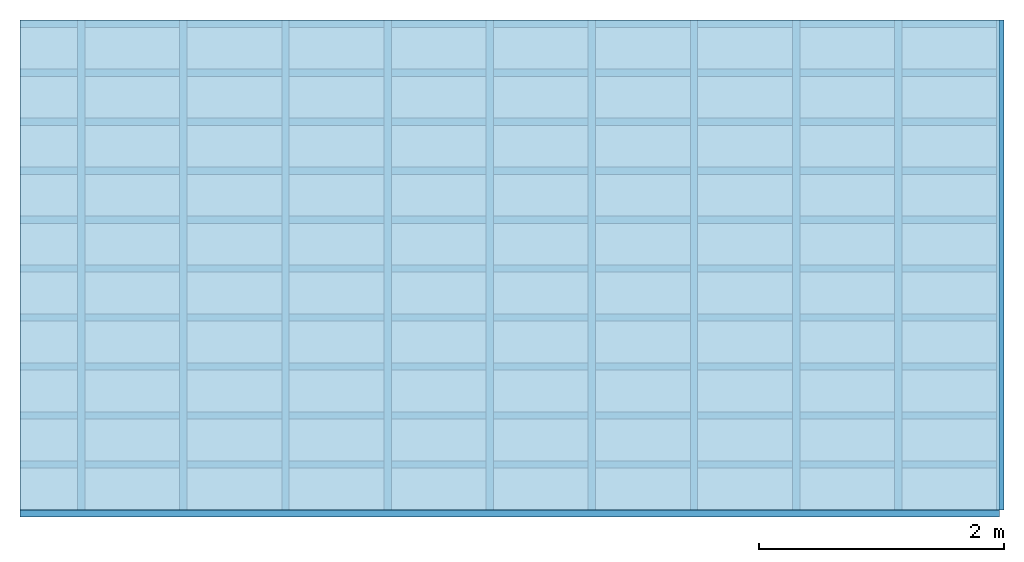
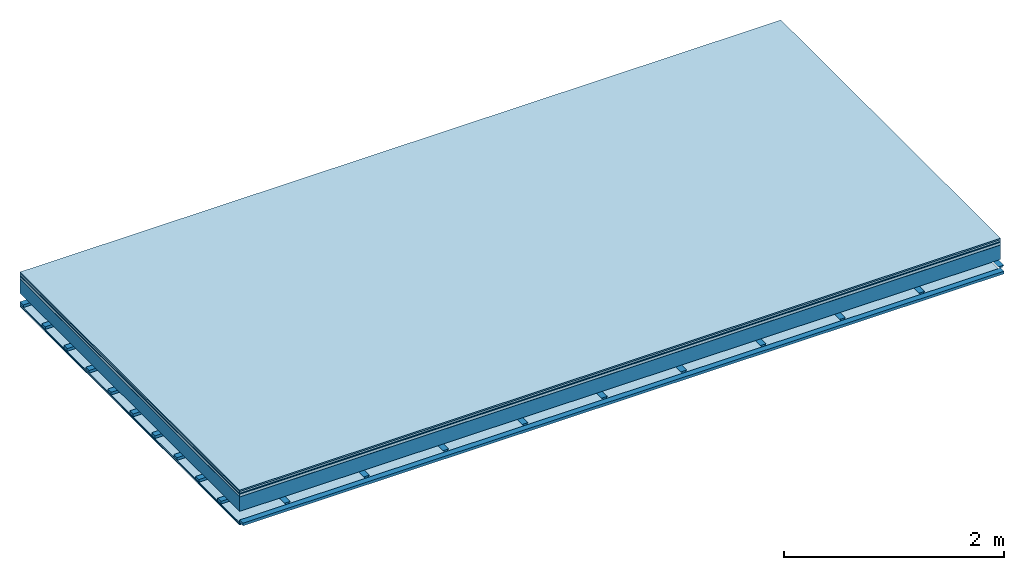
# One storey: 8 plates, 3 members, 1 element without a shape of its own.
"""IFC4 building model written with IfcOpenShell, lengths in metres."""

from ifc_helpers import new_model, si_unit, derived_unit, direction, frame, frame_2d, origin, origin_with_axes, place, context, project, spatial, polyline, rectangle, outline, extrude, material, layer, layer_set, type_object, element, aggregate, save


model = new_model("IFC4")

# Units and contexts
plan_context = context("Plan", 3, precision=1e-05, world=origin(), true_north=direction((0.0, 1.0)))
model_context = context("Model", 3, precision=1e-05, world=origin(), true_north=direction((0.0, 1.0)))
ifc_project = project(units=[si_unit("LENGTHUNIT", "METRE"), derived_unit("SOUNDPRESSUREUNIT", [(si_unit("PRESSUREUNIT", "PASCAL", prefix="MICRO"), 0)]), si_unit("ENERGYUNIT", "JOULE", prefix="MEGA"), si_unit("MASSUNIT", "GRAM", prefix="KILO"), derived_unit("THERMALTRANSMITTANCEUNIT", [(si_unit("POWERUNIT", "WATT"), 1), (si_unit("AREAUNIT", "SQUARE_METRE"), -1), (si_unit("THERMODYNAMICTEMPERATUREUNIT", "KELVIN"), -1)]), derived_unit("AREADENSITYUNIT", [(si_unit("MASSUNIT", "GRAM", prefix="KILO"), 1), (si_unit("AREAUNIT", "SQUARE_METRE"), -1)]), derived_unit("USERDEFINED", [(si_unit("ENERGYUNIT", "JOULE", prefix="MEGA"), 1), (si_unit("AREAUNIT", "SQUARE_METRE"), -1)])], contexts=[plan_context, model_context])

# Site, building, storey
site = spatial("IfcSite", under=ifc_project)
building_placement = place(None, origin())
building = spatial("IfcBuilding", under=site, at=building_placement)
storey_placement = place(building_placement, origin())
storey = spatial("IfcBuildingStorey", under=building, at=storey_placement)

# Slab, members, plates
ifc_material_1 = material(Category="11.013")
ifc_layer_1 = layer(ifc_material_1, 0.015, Name="Flooring")
ifc_material_2 = material(Category="03.007")
ifc_layer_2 = layer(ifc_material_2, 0.02, Name="On-material")
ifc_material_3 = material(Name="Wood fiber generic product", Category="10.009")
ifc_layer_3 = layer(ifc_material_3, 0.01, Name="Impact sound insulation")
ifc_material_4 = material(Name="with broken")
ifc_layer_4 = layer(ifc_material_4, 0.03, Name="on Supporting structure")
ifc_material_5 = material(Name="protection", Category="09.007")
ifc_layer_5 = layer(ifc_material_5, 0.0005, Name="Sub-floor")
ifc_material_6 = material(Name="no composite action")
ifc_layer_6 = layer(ifc_material_6, 0.0, Name="Bond")
ifc_layer_7 = layer(None, 0.16, Name="Supporting structure")
ifc_layer_8 = layer(ifc_material_6, 0.0, Name="Bond")
ifc_layer_9 = layer(None, 0.095, Name="Coupling")
ifc_layer_10 = layer(None, 0.03, Name="Battens / profiles")
ifc_material_7 = material(Name="Plasterboard type A", Category="03.008")
ifc_layer_11 = layer(ifc_material_7, 0.0125, Name="Ceiling covering 1st layer")
ifc_layer_12 = layer(ifc_material_7, 0.0125, Name="Ceiling covering layer 2")
ifc_material_8 = material(Category="04.001")
ifc_layer_13 = layer(ifc_material_8, 0.003, Name="Surface / treatment")
ifc_layer_set = layer_set([ifc_layer_1, ifc_layer_2, ifc_layer_3, ifc_layer_4, ifc_layer_5, ifc_layer_6, ifc_layer_7, ifc_layer_8, ifc_layer_9, ifc_layer_10, ifc_layer_11, ifc_layer_12, ifc_layer_13])
slab_type = type_object("IfcSlabType", Name="A2116", PredefinedType="NOTDEFINED", material=ifc_layer_set)
slab_placement = place(None, frame((0.0, 0.0, 0.0), z_axis=(0.0, 0.0, -1.0), x_axis=(1.0, 0.0, 0.0)))
slab = element("IfcSlab", 1, at=slab_placement, inside=storey, type_object=slab_type, material=ifc_layer_set, Name="Slab #1")
ifc_material_9 = material(Name="Solid timber panel")
member_1_placement = place(slab_placement, origin())
member_1 = element("IfcMember", 2, at=member_1_placement, material=ifc_material_9, Name="Supporting structure", context=plan_context, shape_type="SweptSolid", body=[
    extrude(rectangle(XDim=1.0, YDim=0.16, at=frame_2d((0.5, 0.08), x_axis=(1.0, 0.0))), frame((0.0, 4.0, 0.0755), z_axis=(0.0, -1.0, 0.0), x_axis=(1.0, 0.0, 0.0)), (0.0, 0.0, 1.0), 4.0),
    extrude(rectangle(XDim=1.0, YDim=0.16, at=frame_2d((0.5, 0.08), x_axis=(1.0, 0.0))), frame((1.0, 4.0, 0.0755), z_axis=(0.0, -1.0, 0.0), x_axis=(1.0, 0.0, 0.0)), (0.0, 0.0, 1.0), 4.0),
    extrude(rectangle(XDim=1.0, YDim=0.16, at=frame_2d((0.5, 0.08), x_axis=(1.0, 0.0))), frame((2.0, 4.0, 0.0755), z_axis=(0.0, -1.0, 0.0), x_axis=(1.0, 0.0, 0.0)), (0.0, 0.0, 1.0), 4.0),
    extrude(rectangle(XDim=1.0, YDim=0.16, at=frame_2d((0.5, 0.08), x_axis=(1.0, 0.0))), frame((3.0, 4.0, 0.0755), z_axis=(0.0, -1.0, 0.0), x_axis=(1.0, 0.0, 0.0)), (0.0, 0.0, 1.0), 4.0),
    extrude(rectangle(XDim=1.0, YDim=0.16, at=frame_2d((0.5, 0.08), x_axis=(1.0, 0.0))), frame((4.0, 4.0, 0.0755), z_axis=(0.0, -1.0, 0.0), x_axis=(1.0, 0.0, 0.0)), (0.0, 0.0, 1.0), 4.0),
    extrude(rectangle(XDim=1.0, YDim=0.16, at=frame_2d((0.5, 0.08), x_axis=(1.0, 0.0))), frame((5.0, 4.0, 0.0755), z_axis=(0.0, -1.0, 0.0), x_axis=(1.0, 0.0, 0.0)), (0.0, 0.0, 1.0), 4.0),
    extrude(rectangle(XDim=1.0, YDim=0.16, at=frame_2d((0.5, 0.08), x_axis=(1.0, 0.0))), frame((6.0, 4.0, 0.0755), z_axis=(0.0, -1.0, 0.0), x_axis=(1.0, 0.0, 0.0)), (0.0, 0.0, 1.0), 4.0),
    extrude(rectangle(XDim=1.0, YDim=0.16, at=frame_2d((0.5, 0.08), x_axis=(1.0, 0.0))), frame((7.0, 4.0, 0.0755), z_axis=(0.0, -1.0, 0.0), x_axis=(1.0, 0.0, 0.0)), (0.0, 0.0, 1.0), 4.0),
])
ifc_material_10 = material()
member_2_placement = place(slab_placement, origin())
member_2 = element("IfcMember", 3, at=member_2_placement, material=ifc_material_10, Name="Coupling", context=plan_context, shape_type="SweptSolid", body=[
    extrude(outline(polyline([(0.0, 0.0), (0.06, 0.0), (0.04, 0.02), (0.02, 0.02), (0.0, 0.0)])), frame((0.47, 4.0, 0.3105), z_axis=(0.0, -1.0, 0.0), x_axis=(1.0, 0.0, 0.0)), (0.0, 0.0, 1.0), 4.0),
    extrude(outline(polyline([(0.0, 0.0), (0.06, 0.0), (0.04, 0.02), (0.02, 0.02), (0.0, 0.0)])), frame((1.304, 4.0, 0.3105), z_axis=(0.0, -1.0, 0.0), x_axis=(1.0, 0.0, 0.0)), (0.0, 0.0, 1.0), 4.0),
    extrude(outline(polyline([(0.0, 0.0), (0.06, 0.0), (0.04, 0.02), (0.02, 0.02), (0.0, 0.0)])), frame((2.138, 4.0, 0.3105), z_axis=(0.0, -1.0, 0.0), x_axis=(1.0, 0.0, 0.0)), (0.0, 0.0, 1.0), 4.0),
    extrude(outline(polyline([(0.0, 0.0), (0.06, 0.0), (0.04, 0.02), (0.02, 0.02), (0.0, 0.0)])), frame((2.972, 4.0, 0.3105), z_axis=(0.0, -1.0, 0.0), x_axis=(1.0, 0.0, 0.0)), (0.0, 0.0, 1.0), 4.0),
    extrude(outline(polyline([(0.0, 0.0), (0.06, 0.0), (0.04, 0.02), (0.02, 0.02), (0.0, 0.0)])), frame((3.806, 4.0, 0.3105), z_axis=(0.0, -1.0, 0.0), x_axis=(1.0, 0.0, 0.0)), (0.0, 0.0, 1.0), 4.0),
    extrude(outline(polyline([(0.0, 0.0), (0.06, 0.0), (0.04, 0.02), (0.02, 0.02), (0.0, 0.0)])), frame((4.64, 4.0, 0.3105), z_axis=(0.0, -1.0, 0.0), x_axis=(1.0, 0.0, 0.0)), (0.0, 0.0, 1.0), 4.0),
    extrude(outline(polyline([(0.0, 0.0), (0.06, 0.0), (0.04, 0.02), (0.02, 0.02), (0.0, 0.0)])), frame((5.474, 4.0, 0.3105), z_axis=(0.0, -1.0, 0.0), x_axis=(1.0, 0.0, 0.0)), (0.0, 0.0, 1.0), 4.0),
    extrude(outline(polyline([(0.0, 0.0), (0.06, 0.0), (0.04, 0.02), (0.02, 0.02), (0.0, 0.0)])), frame((6.308, 4.0, 0.3105), z_axis=(0.0, -1.0, 0.0), x_axis=(1.0, 0.0, 0.0)), (0.0, 0.0, 1.0), 4.0),
    extrude(outline(polyline([(0.0, 0.0), (0.06, 0.0), (0.04, 0.02), (0.02, 0.02), (0.0, 0.0)])), frame((7.142, 4.0, 0.3105), z_axis=(0.0, -1.0, 0.0), x_axis=(1.0, 0.0, 0.0)), (0.0, 0.0, 1.0), 4.0),
    extrude(outline(polyline([(0.0, 0.0), (0.06, 0.0), (0.04, 0.02), (0.02, 0.02), (0.0, 0.0)])), frame((7.976, 4.0, 0.3105), z_axis=(0.0, -1.0, 0.0), x_axis=(1.0, 0.0, 0.0)), (0.0, 0.0, 1.0), 4.0),
])
member_3_placement = place(slab_placement, origin())
member_3 = element("IfcMember", 4, at=member_3_placement, material=ifc_material_10, Name="Battens / profiles", context=plan_context, shape_type="SweptSolid", body=[
    extrude(rectangle(XDim=0.06, YDim=0.03, at=frame_2d((0.03, 0.015), x_axis=(1.0, 0.0))), frame((0.0, 0.0, 0.3305), z_axis=(1.0, 0.0, 0.0), x_axis=(0.0, 1.0, 0.0)), (0.0, 0.0, 1.0), 8.0),
    extrude(rectangle(XDim=0.06, YDim=0.03, at=frame_2d((0.03, 0.015), x_axis=(1.0, 0.0))), frame((0.0, 0.4, 0.3305), z_axis=(1.0, 0.0, 0.0), x_axis=(0.0, 1.0, 0.0)), (0.0, 0.0, 1.0), 8.0),
    extrude(rectangle(XDim=0.06, YDim=0.03, at=frame_2d((0.03, 0.015), x_axis=(1.0, 0.0))), frame((0.0, 0.8, 0.3305), z_axis=(1.0, 0.0, 0.0), x_axis=(0.0, 1.0, 0.0)), (0.0, 0.0, 1.0), 8.0),
    extrude(rectangle(XDim=0.06, YDim=0.03, at=frame_2d((0.03, 0.015), x_axis=(1.0, 0.0))), frame((0.0, 1.2, 0.3305), z_axis=(1.0, 0.0, 0.0), x_axis=(0.0, 1.0, 0.0)), (0.0, 0.0, 1.0), 8.0),
    extrude(rectangle(XDim=0.06, YDim=0.03, at=frame_2d((0.03, 0.015), x_axis=(1.0, 0.0))), frame((0.0, 1.6, 0.3305), z_axis=(1.0, 0.0, 0.0), x_axis=(0.0, 1.0, 0.0)), (0.0, 0.0, 1.0), 8.0),
    extrude(rectangle(XDim=0.06, YDim=0.03, at=frame_2d((0.03, 0.015), x_axis=(1.0, 0.0))), frame((0.0, 2.0, 0.3305), z_axis=(1.0, 0.0, 0.0), x_axis=(0.0, 1.0, 0.0)), (0.0, 0.0, 1.0), 8.0),
    extrude(rectangle(XDim=0.06, YDim=0.03, at=frame_2d((0.03, 0.015), x_axis=(1.0, 0.0))), frame((0.0, 2.4, 0.3305), z_axis=(1.0, 0.0, 0.0), x_axis=(0.0, 1.0, 0.0)), (0.0, 0.0, 1.0), 8.0),
    extrude(rectangle(XDim=0.06, YDim=0.03, at=frame_2d((0.03, 0.015), x_axis=(1.0, 0.0))), frame((0.0, 2.8, 0.3305), z_axis=(1.0, 0.0, 0.0), x_axis=(0.0, 1.0, 0.0)), (0.0, 0.0, 1.0), 8.0),
    extrude(rectangle(XDim=0.06, YDim=0.03, at=frame_2d((0.03, 0.015), x_axis=(1.0, 0.0))), frame((0.0, 3.2, 0.3305), z_axis=(1.0, 0.0, 0.0), x_axis=(0.0, 1.0, 0.0)), (0.0, 0.0, 1.0), 8.0),
    extrude(rectangle(XDim=0.06, YDim=0.03, at=frame_2d((0.03, 0.015), x_axis=(1.0, 0.0))), frame((0.0, 3.6, 0.3305), z_axis=(1.0, 0.0, 0.0), x_axis=(0.0, 1.0, 0.0)), (0.0, 0.0, 1.0), 8.0),
    extrude(rectangle(XDim=0.06, YDim=0.03, at=frame_2d((0.03, 0.015), x_axis=(1.0, 0.0))), frame((0.0, 4.0, 0.3305), z_axis=(1.0, 0.0, 0.0), x_axis=(0.0, 1.0, 0.0)), (0.0, 0.0, 1.0), 8.0),
])
plate_1_placement = place(slab_placement, origin())
plate_1 = element("IfcPlate", 5, at=plate_1_placement, material=ifc_material_1, Name="Flooring", context=plan_context, shape_type="SweptSolid", body=[
    extrude(rectangle(XDim=8.0, YDim=4.0, at=frame_2d((4.0, 2.0), x_axis=(1.0, 0.0))), origin_with_axes(), (0.0, 0.0, 1.0), 0.015),
])
plate_2_placement = place(slab_placement, origin())
plate_2 = element("IfcPlate", 6, at=plate_2_placement, material=ifc_material_2, Name="On-material", context=plan_context, shape_type="SweptSolid", body=[
    extrude(rectangle(XDim=8.0, YDim=4.0, at=frame_2d((4.0, 2.0), x_axis=(1.0, 0.0))), frame((0.0, 0.0, 0.015), z_axis=(0.0, 0.0, 1.0), x_axis=(1.0, 0.0, 0.0)), (0.0, 0.0, 1.0), 0.02),
])
plate_3_placement = place(slab_placement, origin())
plate_3 = element("IfcPlate", 7, at=plate_3_placement, material=ifc_material_3, Name="Impact sound insulation", context=plan_context, shape_type="SweptSolid", body=[
    extrude(rectangle(XDim=8.0, YDim=4.0, at=frame_2d((4.0, 2.0), x_axis=(1.0, 0.0))), frame((0.0, 0.0, 0.035), z_axis=(0.0, 0.0, 1.0), x_axis=(1.0, 0.0, 0.0)), (0.0, 0.0, 1.0), 0.01),
])
plate_4_placement = place(slab_placement, origin())
plate_4 = element("IfcPlate", 8, at=plate_4_placement, material=ifc_material_4, Name="on Supporting structure", context=plan_context, shape_type="SweptSolid", body=[
    extrude(rectangle(XDim=8.0, YDim=4.0, at=frame_2d((4.0, 2.0), x_axis=(1.0, 0.0))), frame((0.0, 0.0, 0.045), z_axis=(0.0, 0.0, 1.0), x_axis=(1.0, 0.0, 0.0)), (0.0, 0.0, 1.0), 0.03),
])
plate_5_placement = place(slab_placement, origin())
plate_5 = element("IfcPlate", 9, at=plate_5_placement, material=ifc_material_5, Name="Sub-floor", context=plan_context, shape_type="SweptSolid", body=[
    extrude(rectangle(XDim=8.0, YDim=4.0, at=frame_2d((4.0, 2.0), x_axis=(1.0, 0.0))), frame((0.0, 0.0, 0.075), z_axis=(0.0, 0.0, 1.0), x_axis=(1.0, 0.0, 0.0)), (0.0, 0.0, 1.0), 0.0005),
])
plate_6_placement = place(slab_placement, origin())
plate_6 = element("IfcPlate", 10, at=plate_6_placement, material=ifc_material_7, Name="Ceiling covering 1st layer", context=plan_context, shape_type="SweptSolid", body=[
    extrude(rectangle(XDim=8.0, YDim=4.0, at=frame_2d((4.0, 2.0), x_axis=(1.0, 0.0))), frame((0.0, 0.0, 0.3605), z_axis=(0.0, 0.0, 1.0), x_axis=(1.0, 0.0, 0.0)), (0.0, 0.0, 1.0), 0.0125),
])
plate_7_placement = place(slab_placement, origin())
plate_7 = element("IfcPlate", 11, at=plate_7_placement, material=ifc_material_7, Name="Ceiling covering layer 2", context=plan_context, shape_type="SweptSolid", body=[
    extrude(rectangle(XDim=8.0, YDim=4.0, at=frame_2d((4.0, 2.0), x_axis=(1.0, 0.0))), frame((0.0, 0.0, 0.373), z_axis=(0.0, 0.0, 1.0), x_axis=(1.0, 0.0, 0.0)), (0.0, 0.0, 1.0), 0.0125),
])
plate_8_placement = place(slab_placement, origin())
plate_8 = element("IfcPlate", 12, at=plate_8_placement, material=ifc_material_8, Name="Surface / treatment", context=plan_context, shape_type="SweptSolid", body=[
    extrude(rectangle(XDim=8.0, YDim=4.0, at=frame_2d((4.0, 2.0), x_axis=(1.0, 0.0))), frame((0.0, 0.0, 0.3855), z_axis=(0.0, 0.0, 1.0), x_axis=(1.0, 0.0, 0.0)), (0.0, 0.0, 1.0), 0.003),
])
aggregate(slab, [plate_1, plate_2, plate_3, plate_4, plate_5, member_1, member_2, member_3, plate_6, plate_7, plate_8])

save(model, "model.ifc")
